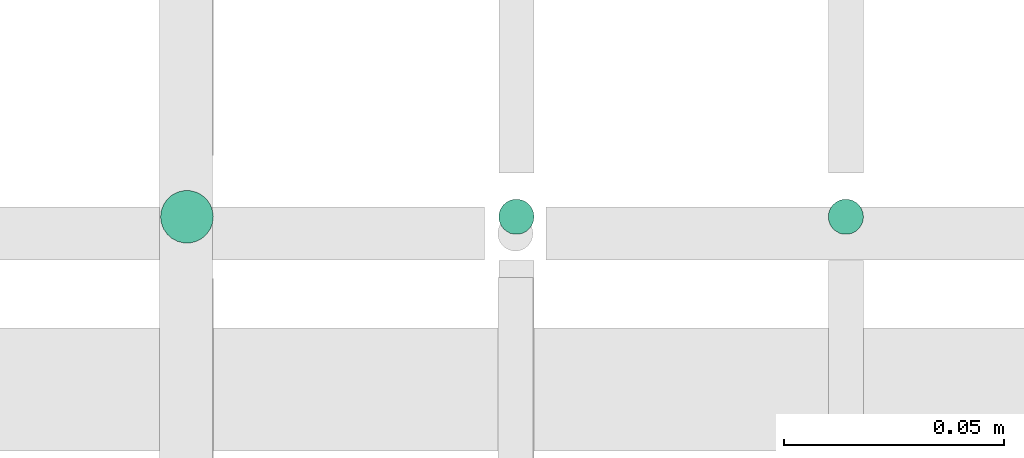
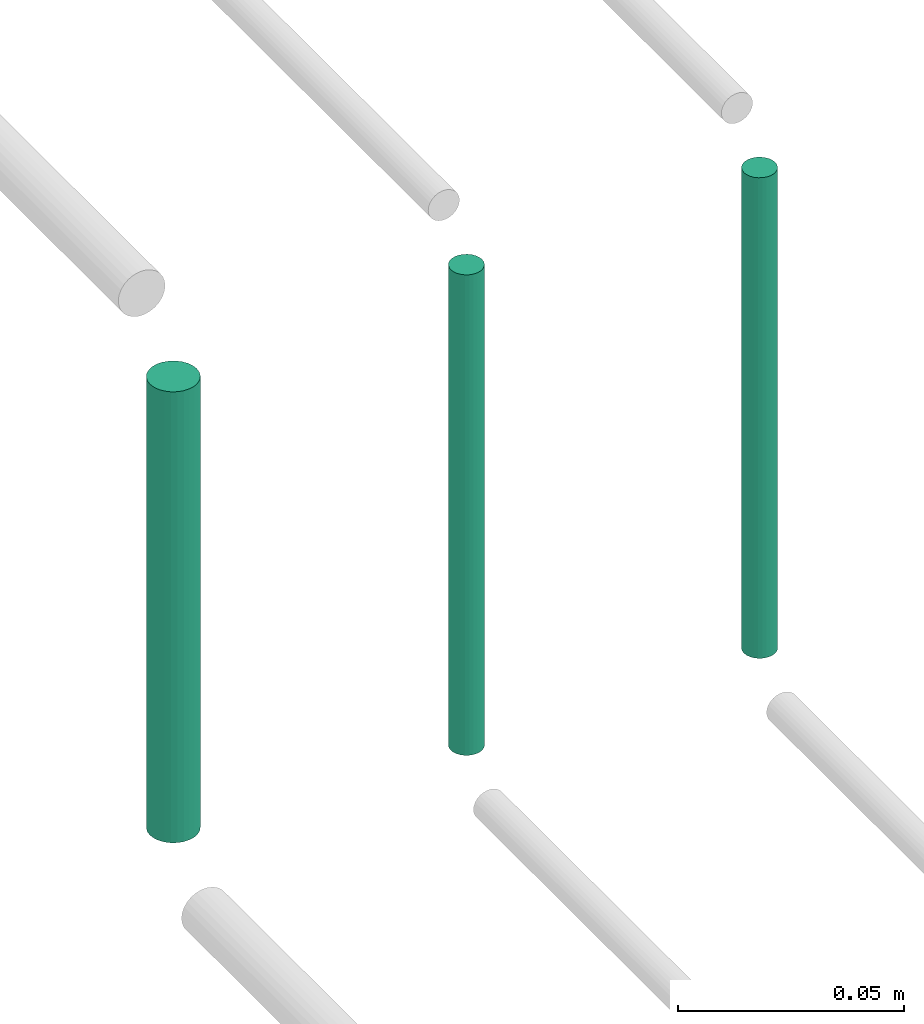
# One storey, part 156 of 331: 3 flow segments.
"""IFC2X3 building model written with IfcOpenShell, lengths in millimetres."""

from ifc_helpers import new_model, entity, si_unit, converted_unit, derived_unit, direction, frame, origin, origin_2d_with_axis, place, context, subcontext, project, spatial, circle, extrude, type_object, element, save


model = new_model("IFC2X3")

# Units and contexts
model_context = context("Model", 3, precision=0.01, world=origin(), true_north=direction((6.12303176911189e-17, 1.0)))
body_context = subcontext(model_context, "Body", "Model", "MODEL_VIEW")
ifc_project = project(units=[si_unit("LENGTHUNIT", "METRE", prefix="MILLI"), si_unit("AREAUNIT", "SQUARE_METRE"), si_unit("VOLUMEUNIT", "CUBIC_METRE"), converted_unit("PLANEANGLEUNIT", "DEGREE", entity("IfcRatioMeasure", 0.0174532925199433), si_unit("PLANEANGLEUNIT", "RADIAN"), dimensions=[0, 0, 0, 0, 0, 0, 0]), si_unit("MASSUNIT", "GRAM", prefix="KILO"), derived_unit("MASSDENSITYUNIT", [(si_unit("MASSUNIT", "GRAM", prefix="KILO"), 1), (si_unit("LENGTHUNIT", "METRE"), -3)]), derived_unit("MOMENTOFINERTIAUNIT", [(si_unit("LENGTHUNIT", "METRE"), 4)]), si_unit("TIMEUNIT", "SECOND"), si_unit("FREQUENCYUNIT", "HERTZ"), si_unit("THERMODYNAMICTEMPERATUREUNIT", "DEGREE_CELSIUS"), derived_unit("THERMALTRANSMITTANCEUNIT", [(si_unit("MASSUNIT", "GRAM", prefix="KILO"), 1), (si_unit("THERMODYNAMICTEMPERATUREUNIT", "KELVIN"), -1), (si_unit("TIMEUNIT", "SECOND"), -3)]), derived_unit("VOLUMETRICFLOWRATEUNIT", [(si_unit("LENGTHUNIT", "METRE"), 3), (si_unit("TIMEUNIT", "SECOND"), -1)]), derived_unit("MASSFLOWRATEUNIT", [(si_unit("MASSUNIT", "GRAM", prefix="KILO"), 1), (si_unit("TIMEUNIT", "SECOND"), -1)]), derived_unit("ROTATIONALFREQUENCYUNIT", [(si_unit("TIMEUNIT", "SECOND"), -1)]), si_unit("ELECTRICCURRENTUNIT", "AMPERE"), si_unit("ELECTRICVOLTAGEUNIT", "VOLT"), si_unit("POWERUNIT", "WATT"), si_unit("FORCEUNIT", "NEWTON", prefix="KILO"), si_unit("ILLUMINANCEUNIT", "LUX"), si_unit("LUMINOUSFLUXUNIT", "LUMEN"), si_unit("LUMINOUSINTENSITYUNIT", "CANDELA"), derived_unit("USERDEFINED", [(si_unit("MASSUNIT", "GRAM", prefix="KILO"), -1), (si_unit("LENGTHUNIT", "METRE"), -2), (si_unit("TIMEUNIT", "SECOND"), 3), (si_unit("LUMINOUSFLUXUNIT", "LUMEN"), 1)]), derived_unit("LINEARVELOCITYUNIT", [(si_unit("LENGTHUNIT", "METRE"), 1), (si_unit("TIMEUNIT", "SECOND"), -1)]), si_unit("PRESSUREUNIT", "PASCAL"), derived_unit("USERDEFINED", [(si_unit("LENGTHUNIT", "METRE"), -2), (si_unit("MASSUNIT", "GRAM", prefix="KILO"), 1), (si_unit("TIMEUNIT", "SECOND"), -2)]), derived_unit("LINEARFORCEUNIT", [(si_unit("MASSUNIT", "GRAM", prefix="KILO"), 1), (si_unit("LENGTHUNIT", "METRE"), 1), (si_unit("TIMEUNIT", "SECOND"), -2), (si_unit("LENGTHUNIT", "METRE"), -1)]), derived_unit("PLANARFORCEUNIT", [(si_unit("MASSUNIT", "GRAM", prefix="KILO"), 1), (si_unit("LENGTHUNIT", "METRE"), 1), (si_unit("TIMEUNIT", "SECOND"), -2), (si_unit("LENGTHUNIT", "METRE"), -2)])], contexts=[model_context])

# Site, building, storey
site_placement = place(None, frame((0.0, -0.00077364408347762, 0.0)))
site = spatial("IfcSite", under=ifc_project, at=site_placement, CompositionType="ELEMENT")
building_placement = place(site_placement, origin())
building = spatial("IfcBuilding", under=site, at=building_placement, CompositionType="ELEMENT")
storey_placement = place(building_placement, origin())
storey = spatial("IfcBuildingStorey", under=building, at=storey_placement, CompositionType="ELEMENT", Elevation=0.0)

# Flow segments
pipe_segment_type = type_object("IfcPipeSegmentType", PredefinedType="NOTDEFINED")
flow_segment_1_placement = place(storey_placement, frame((35690.7427281405, 8229.21546224644, 18660.0)))
element("IfcFlowSegment", 1, at=flow_segment_1_placement, inside=storey, type_object=pipe_segment_type, context=body_context, shape_type="SweptSolid", body=[
    extrude(circle(Radius=4.0, at=origin_2d_with_axis()), frame((5.59527223591499, 5.59527223591607, 0.0)), (0.0, 0.0, 1.0), 130.000000000025),
])
flow_segment_2_placement = place(storey_placement, frame((35613.7427281405, 8227.21546224644, 18664.0)))
element("IfcFlowSegment", 2, at=flow_segment_2_placement, inside=storey, type_object=pipe_segment_type, context=body_context, shape_type="SweptSolid", body=[
    extrude(circle(Radius=6.0, at=origin_2d_with_axis()), frame((7.59527223591454, 7.59527223591562, 0.0)), (0.0, 0.0, 1.0), 122.00000000002),
])
flow_segment_3_placement = place(building_placement, frame((35765.7427281405, 8229.21546224644, 18660.0)))
element("IfcFlowSegment", 3, at=flow_segment_3_placement, inside=storey, type_object=pipe_segment_type, context=body_context, shape_type="SweptSolid", body=[
    extrude(circle(Radius=4.0, at=origin_2d_with_axis()), frame((5.59527223591499, 5.59527223591607, 0.0)), (0.0, 0.0, 1.0), 130.000000000048),
])

save(model, "model.ifc")
